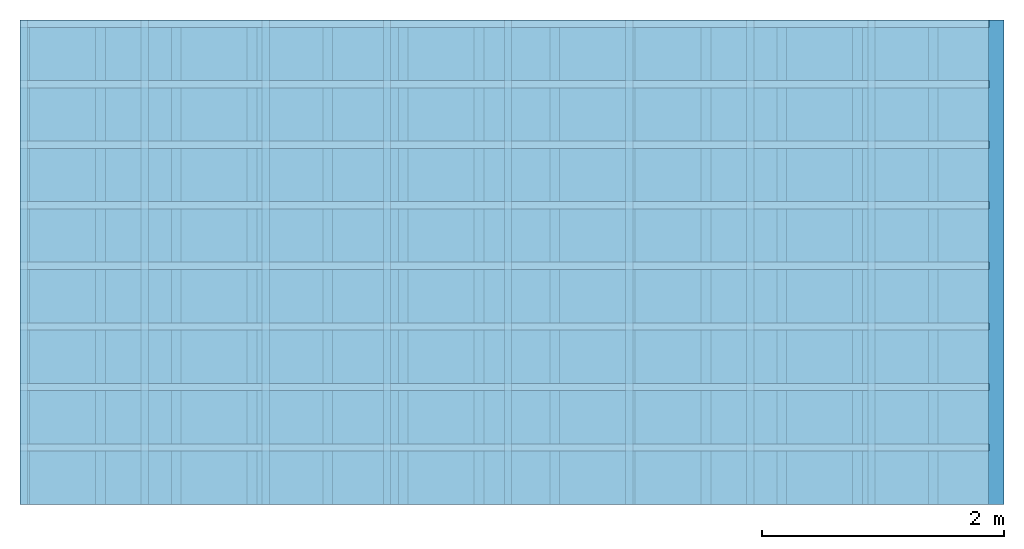
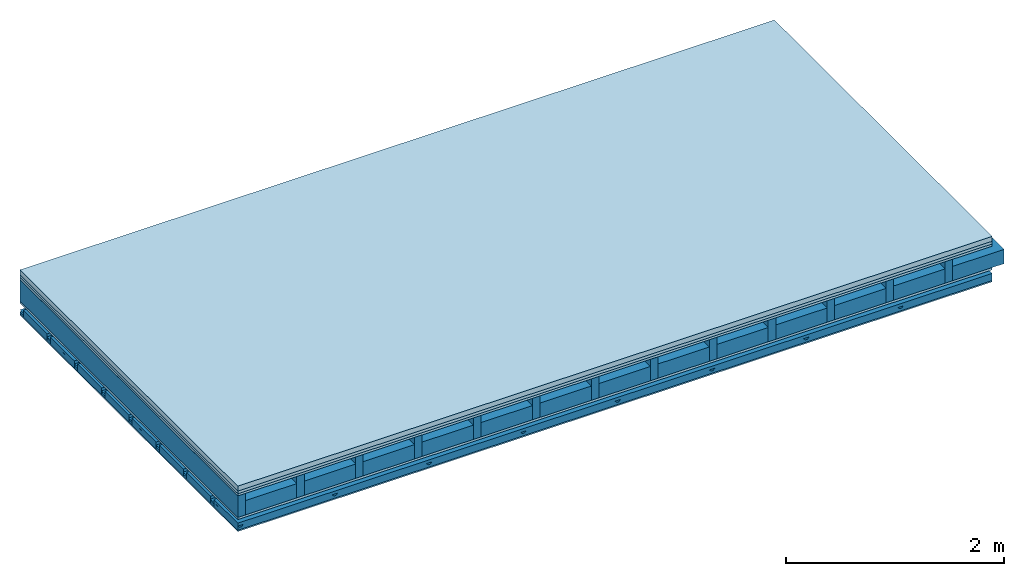
# One storey: 5 members, 5 plates, 1 element without a shape of its own.
"""IFC4 building model written with IfcOpenShell, lengths in metres."""

from ifc_helpers import new_model, si_unit, derived_unit, direction, frame, frame_2d, origin, origin_with_axes, place, context, project, spatial, polyline, rectangle, outline, extrude, material, layer, layer_set, type_object, element, aggregate, save


model = new_model("IFC4")

# Units and contexts
plan_context = context("Plan", 3, precision=1e-05, world=origin(), true_north=direction((0.0, 1.0)))
model_context = context("Model", 3, precision=1e-05, world=origin(), true_north=direction((0.0, 1.0)))
ifc_project = project(units=[si_unit("LENGTHUNIT", "METRE"), derived_unit("SOUNDPRESSUREUNIT", [(si_unit("PRESSUREUNIT", "PASCAL", prefix="MICRO"), 0)]), si_unit("ENERGYUNIT", "JOULE", prefix="MEGA"), si_unit("MASSUNIT", "GRAM", prefix="KILO"), derived_unit("THERMALTRANSMITTANCEUNIT", [(si_unit("POWERUNIT", "WATT"), 1), (si_unit("AREAUNIT", "SQUARE_METRE"), -1), (si_unit("THERMODYNAMICTEMPERATUREUNIT", "KELVIN"), -1)]), derived_unit("AREADENSITYUNIT", [(si_unit("MASSUNIT", "GRAM", prefix="KILO"), 1), (si_unit("AREAUNIT", "SQUARE_METRE"), -1)]), derived_unit("USERDEFINED", [(si_unit("ENERGYUNIT", "JOULE", prefix="MEGA"), 1), (si_unit("AREAUNIT", "SQUARE_METRE"), -1)])], contexts=[plan_context, model_context])

# Site, building, storey
site = spatial("IfcSite", under=ifc_project)
building_placement = place(None, origin())
building = spatial("IfcBuilding", under=site, at=building_placement)
storey_placement = place(building_placement, origin())
storey = spatial("IfcBuildingStorey", under=building, at=storey_placement)

# Slab, members, plates
ifc_material_1 = material(Category="04.005")
ifc_layer_1 = layer(ifc_material_1, 0.055, Name="On-material")
ifc_material_2 = material()
ifc_layer_2 = layer(ifc_material_2, 0.03, Name="Impact sound insulation")
ifc_material_3 = material(Category="07.001")
ifc_layer_3 = layer(ifc_material_3, 0.025, Name="Sub-floor")
ifc_material_4 = material(Name="Rigid, of the art")
ifc_layer_4 = layer(ifc_material_4, 0.0, Name="Bond")
ifc_layer_5 = layer(None, 0.24, Name="Supporting structure")
ifc_layer_6 = layer(ifc_material_4, 0.0, Name="Bond")
ifc_layer_7 = layer(ifc_material_3, 0.025, Name="Lower layer 1")
ifc_layer_8 = layer(None, 0.093, Name="Coupling")
ifc_layer_9 = layer(None, 0.027, Name="Battens / profiles")
ifc_material_5 = material(Category="03.007")
ifc_layer_10 = layer(ifc_material_5, 0.015, Name="Ceiling covering 1st layer")
ifc_material_6 = material(Name="Glued joints")
ifc_layer_11 = layer(ifc_material_6, 0.0, Name="Surface / treatment")
ifc_layer_set = layer_set([ifc_layer_1, ifc_layer_2, ifc_layer_3, ifc_layer_4, ifc_layer_5, ifc_layer_6, ifc_layer_7, ifc_layer_8, ifc_layer_9, ifc_layer_10, ifc_layer_11])
slab_type = type_object("IfcSlabType", Name="A0755", PredefinedType="NOTDEFINED", material=ifc_layer_set)
slab_placement = place(None, frame((0.0, 0.0, 0.0), z_axis=(0.0, 0.0, -1.0), x_axis=(1.0, 0.0, 0.0)))
slab = element("IfcSlab", 1, at=slab_placement, inside=storey, type_object=slab_type, material=ifc_layer_set, Name="Slab #1")
ifc_material_7 = material()
member_1_placement = place(slab_placement, origin())
member_1 = element("IfcMember", 2, at=member_1_placement, material=ifc_material_7, Name="Supporting structure", context=plan_context, shape_type="SweptSolid", body=[
    extrude(rectangle(XDim=0.08, YDim=0.24, at=frame_2d((0.04, 0.12), x_axis=(1.0, 0.0))), frame((0.0, 4.0, 0.11), z_axis=(0.0, -1.0, 0.0), x_axis=(1.0, 0.0, 0.0)), (0.0, 0.0, 1.0), 4.0),
    extrude(rectangle(XDim=0.08, YDim=0.24, at=frame_2d((0.04, 0.12), x_axis=(1.0, 0.0))), frame((0.625, 4.0, 0.11), z_axis=(0.0, -1.0, 0.0), x_axis=(1.0, 0.0, 0.0)), (0.0, 0.0, 1.0), 4.0),
    extrude(rectangle(XDim=0.08, YDim=0.24, at=frame_2d((0.04, 0.12), x_axis=(1.0, 0.0))), frame((1.25, 4.0, 0.11), z_axis=(0.0, -1.0, 0.0), x_axis=(1.0, 0.0, 0.0)), (0.0, 0.0, 1.0), 4.0),
    extrude(rectangle(XDim=0.08, YDim=0.24, at=frame_2d((0.04, 0.12), x_axis=(1.0, 0.0))), frame((1.875, 4.0, 0.11), z_axis=(0.0, -1.0, 0.0), x_axis=(1.0, 0.0, 0.0)), (0.0, 0.0, 1.0), 4.0),
    extrude(rectangle(XDim=0.08, YDim=0.24, at=frame_2d((0.04, 0.12), x_axis=(1.0, 0.0))), frame((2.5, 4.0, 0.11), z_axis=(0.0, -1.0, 0.0), x_axis=(1.0, 0.0, 0.0)), (0.0, 0.0, 1.0), 4.0),
    extrude(rectangle(XDim=0.08, YDim=0.24, at=frame_2d((0.04, 0.12), x_axis=(1.0, 0.0))), frame((3.125, 4.0, 0.11), z_axis=(0.0, -1.0, 0.0), x_axis=(1.0, 0.0, 0.0)), (0.0, 0.0, 1.0), 4.0),
    extrude(rectangle(XDim=0.08, YDim=0.24, at=frame_2d((0.04, 0.12), x_axis=(1.0, 0.0))), frame((3.75, 4.0, 0.11), z_axis=(0.0, -1.0, 0.0), x_axis=(1.0, 0.0, 0.0)), (0.0, 0.0, 1.0), 4.0),
    extrude(rectangle(XDim=0.08, YDim=0.24, at=frame_2d((0.04, 0.12), x_axis=(1.0, 0.0))), frame((4.375, 4.0, 0.11), z_axis=(0.0, -1.0, 0.0), x_axis=(1.0, 0.0, 0.0)), (0.0, 0.0, 1.0), 4.0),
    extrude(rectangle(XDim=0.08, YDim=0.24, at=frame_2d((0.04, 0.12), x_axis=(1.0, 0.0))), frame((5.0, 4.0, 0.11), z_axis=(0.0, -1.0, 0.0), x_axis=(1.0, 0.0, 0.0)), (0.0, 0.0, 1.0), 4.0),
    extrude(rectangle(XDim=0.08, YDim=0.24, at=frame_2d((0.04, 0.12), x_axis=(1.0, 0.0))), frame((5.625, 4.0, 0.11), z_axis=(0.0, -1.0, 0.0), x_axis=(1.0, 0.0, 0.0)), (0.0, 0.0, 1.0), 4.0),
    extrude(rectangle(XDim=0.08, YDim=0.24, at=frame_2d((0.04, 0.12), x_axis=(1.0, 0.0))), frame((6.25, 4.0, 0.11), z_axis=(0.0, -1.0, 0.0), x_axis=(1.0, 0.0, 0.0)), (0.0, 0.0, 1.0), 4.0),
    extrude(rectangle(XDim=0.08, YDim=0.24, at=frame_2d((0.04, 0.12), x_axis=(1.0, 0.0))), frame((6.875, 4.0, 0.11), z_axis=(0.0, -1.0, 0.0), x_axis=(1.0, 0.0, 0.0)), (0.0, 0.0, 1.0), 4.0),
    extrude(rectangle(XDim=0.08, YDim=0.24, at=frame_2d((0.04, 0.12), x_axis=(1.0, 0.0))), frame((7.5, 4.0, 0.11), z_axis=(0.0, -1.0, 0.0), x_axis=(1.0, 0.0, 0.0)), (0.0, 0.0, 1.0), 4.0),
])
ifc_material_8 = material()
member_2_placement = place(slab_placement, origin())
member_2 = element("IfcMember", 3, at=member_2_placement, material=ifc_material_8, Name="in supporting structure", context=plan_context, shape_type="SweptSolid", body=[
    extrude(rectangle(XDim=0.545, YDim=0.16, at=frame_2d((0.2725, 0.08), x_axis=(1.0, 0.0))), frame((0.08, 4.0, 0.19), z_axis=(0.0, -1.0, 0.0), x_axis=(1.0, 0.0, 0.0)), (0.0, 0.0, 1.0), 4.0),
    extrude(rectangle(XDim=0.545, YDim=0.16, at=frame_2d((0.2725, 0.08), x_axis=(1.0, 0.0))), frame((0.705, 4.0, 0.19), z_axis=(0.0, -1.0, 0.0), x_axis=(1.0, 0.0, 0.0)), (0.0, 0.0, 1.0), 4.0),
    extrude(rectangle(XDim=0.545, YDim=0.16, at=frame_2d((0.2725, 0.08), x_axis=(1.0, 0.0))), frame((1.33, 4.0, 0.19), z_axis=(0.0, -1.0, 0.0), x_axis=(1.0, 0.0, 0.0)), (0.0, 0.0, 1.0), 4.0),
    extrude(rectangle(XDim=0.545, YDim=0.16, at=frame_2d((0.2725, 0.08), x_axis=(1.0, 0.0))), frame((1.955, 4.0, 0.19), z_axis=(0.0, -1.0, 0.0), x_axis=(1.0, 0.0, 0.0)), (0.0, 0.0, 1.0), 4.0),
    extrude(rectangle(XDim=0.545, YDim=0.16, at=frame_2d((0.2725, 0.08), x_axis=(1.0, 0.0))), frame((2.58, 4.0, 0.19), z_axis=(0.0, -1.0, 0.0), x_axis=(1.0, 0.0, 0.0)), (0.0, 0.0, 1.0), 4.0),
    extrude(rectangle(XDim=0.545, YDim=0.16, at=frame_2d((0.2725, 0.08), x_axis=(1.0, 0.0))), frame((3.205, 4.0, 0.19), z_axis=(0.0, -1.0, 0.0), x_axis=(1.0, 0.0, 0.0)), (0.0, 0.0, 1.0), 4.0),
    extrude(rectangle(XDim=0.545, YDim=0.16, at=frame_2d((0.2725, 0.08), x_axis=(1.0, 0.0))), frame((3.83, 4.0, 0.19), z_axis=(0.0, -1.0, 0.0), x_axis=(1.0, 0.0, 0.0)), (0.0, 0.0, 1.0), 4.0),
    extrude(rectangle(XDim=0.545, YDim=0.16, at=frame_2d((0.2725, 0.08), x_axis=(1.0, 0.0))), frame((4.455, 4.0, 0.19), z_axis=(0.0, -1.0, 0.0), x_axis=(1.0, 0.0, 0.0)), (0.0, 0.0, 1.0), 4.0),
    extrude(rectangle(XDim=0.545, YDim=0.16, at=frame_2d((0.2725, 0.08), x_axis=(1.0, 0.0))), frame((5.08, 4.0, 0.19), z_axis=(0.0, -1.0, 0.0), x_axis=(1.0, 0.0, 0.0)), (0.0, 0.0, 1.0), 4.0),
    extrude(rectangle(XDim=0.545, YDim=0.16, at=frame_2d((0.2725, 0.08), x_axis=(1.0, 0.0))), frame((5.705, 4.0, 0.19), z_axis=(0.0, -1.0, 0.0), x_axis=(1.0, 0.0, 0.0)), (0.0, 0.0, 1.0), 4.0),
    extrude(rectangle(XDim=0.545, YDim=0.16, at=frame_2d((0.2725, 0.08), x_axis=(1.0, 0.0))), frame((6.33, 4.0, 0.19), z_axis=(0.0, -1.0, 0.0), x_axis=(1.0, 0.0, 0.0)), (0.0, 0.0, 1.0), 4.0),
    extrude(rectangle(XDim=0.545, YDim=0.16, at=frame_2d((0.2725, 0.08), x_axis=(1.0, 0.0))), frame((6.955, 4.0, 0.19), z_axis=(0.0, -1.0, 0.0), x_axis=(1.0, 0.0, 0.0)), (0.0, 0.0, 1.0), 4.0),
    extrude(rectangle(XDim=0.545, YDim=0.16, at=frame_2d((0.2725, 0.08), x_axis=(1.0, 0.0))), frame((7.58, 4.0, 0.19), z_axis=(0.0, -1.0, 0.0), x_axis=(1.0, 0.0, 0.0)), (0.0, 0.0, 1.0), 4.0),
])
ifc_material_9 = material()
member_3_placement = place(slab_placement, origin())
member_3 = element("IfcMember", 4, at=member_3_placement, material=ifc_material_9, Name="Coupling", context=plan_context, shape_type="SweptSolid", body=[
    extrude(outline(polyline([(0.0, 0.0), (0.06, 0.0), (0.04, 0.02), (0.02, 0.02), (0.0, 0.0)])), frame((0.0, 4.0, 0.448), z_axis=(0.0, -1.0, 0.0), x_axis=(1.0, 0.0, 0.0)), (0.0, 0.0, 1.0), 4.0),
    extrude(outline(polyline([(0.0, 0.0), (0.06, 0.0), (0.04, 0.02), (0.02, 0.02), (0.0, 0.0)])), frame((1.0, 4.0, 0.448), z_axis=(0.0, -1.0, 0.0), x_axis=(1.0, 0.0, 0.0)), (0.0, 0.0, 1.0), 4.0),
    extrude(outline(polyline([(0.0, 0.0), (0.06, 0.0), (0.04, 0.02), (0.02, 0.02), (0.0, 0.0)])), frame((2.0, 4.0, 0.448), z_axis=(0.0, -1.0, 0.0), x_axis=(1.0, 0.0, 0.0)), (0.0, 0.0, 1.0), 4.0),
    extrude(outline(polyline([(0.0, 0.0), (0.06, 0.0), (0.04, 0.02), (0.02, 0.02), (0.0, 0.0)])), frame((3.0, 4.0, 0.448), z_axis=(0.0, -1.0, 0.0), x_axis=(1.0, 0.0, 0.0)), (0.0, 0.0, 1.0), 4.0),
    extrude(outline(polyline([(0.0, 0.0), (0.06, 0.0), (0.04, 0.02), (0.02, 0.02), (0.0, 0.0)])), frame((4.0, 4.0, 0.448), z_axis=(0.0, -1.0, 0.0), x_axis=(1.0, 0.0, 0.0)), (0.0, 0.0, 1.0), 4.0),
    extrude(outline(polyline([(0.0, 0.0), (0.06, 0.0), (0.04, 0.02), (0.02, 0.02), (0.0, 0.0)])), frame((5.0, 4.0, 0.448), z_axis=(0.0, -1.0, 0.0), x_axis=(1.0, 0.0, 0.0)), (0.0, 0.0, 1.0), 4.0),
    extrude(outline(polyline([(0.0, 0.0), (0.06, 0.0), (0.04, 0.02), (0.02, 0.02), (0.0, 0.0)])), frame((6.0, 4.0, 0.448), z_axis=(0.0, -1.0, 0.0), x_axis=(1.0, 0.0, 0.0)), (0.0, 0.0, 1.0), 4.0),
    extrude(outline(polyline([(0.0, 0.0), (0.06, 0.0), (0.04, 0.02), (0.02, 0.02), (0.0, 0.0)])), frame((7.0, 4.0, 0.448), z_axis=(0.0, -1.0, 0.0), x_axis=(1.0, 0.0, 0.0)), (0.0, 0.0, 1.0), 4.0),
])
ifc_material_10 = material()
member_4_placement = place(slab_placement, origin())
member_4 = element("IfcMember", 5, at=member_4_placement, material=ifc_material_10, Name="Battens / profiles", context=plan_context, shape_type="SweptSolid", body=[
    extrude(rectangle(XDim=0.06, YDim=0.027, at=frame_2d((0.03, 0.0135), x_axis=(1.0, 0.0))), frame((0.0, 0.0, 0.468), z_axis=(1.0, 0.0, 0.0), x_axis=(0.0, 1.0, 0.0)), (0.0, 0.0, 1.0), 8.0),
    extrude(rectangle(XDim=0.06, YDim=0.027, at=frame_2d((0.03, 0.0135), x_axis=(1.0, 0.0))), frame((0.0, 0.5, 0.468), z_axis=(1.0, 0.0, 0.0), x_axis=(0.0, 1.0, 0.0)), (0.0, 0.0, 1.0), 8.0),
    extrude(rectangle(XDim=0.06, YDim=0.027, at=frame_2d((0.03, 0.0135), x_axis=(1.0, 0.0))), frame((0.0, 1.0, 0.468), z_axis=(1.0, 0.0, 0.0), x_axis=(0.0, 1.0, 0.0)), (0.0, 0.0, 1.0), 8.0),
    extrude(rectangle(XDim=0.06, YDim=0.027, at=frame_2d((0.03, 0.0135), x_axis=(1.0, 0.0))), frame((0.0, 1.5, 0.468), z_axis=(1.0, 0.0, 0.0), x_axis=(0.0, 1.0, 0.0)), (0.0, 0.0, 1.0), 8.0),
    extrude(rectangle(XDim=0.06, YDim=0.027, at=frame_2d((0.03, 0.0135), x_axis=(1.0, 0.0))), frame((0.0, 2.0, 0.468), z_axis=(1.0, 0.0, 0.0), x_axis=(0.0, 1.0, 0.0)), (0.0, 0.0, 1.0), 8.0),
    extrude(rectangle(XDim=0.06, YDim=0.027, at=frame_2d((0.03, 0.0135), x_axis=(1.0, 0.0))), frame((0.0, 2.5, 0.468), z_axis=(1.0, 0.0, 0.0), x_axis=(0.0, 1.0, 0.0)), (0.0, 0.0, 1.0), 8.0),
    extrude(rectangle(XDim=0.06, YDim=0.027, at=frame_2d((0.03, 0.0135), x_axis=(1.0, 0.0))), frame((0.0, 3.0, 0.468), z_axis=(1.0, 0.0, 0.0), x_axis=(0.0, 1.0, 0.0)), (0.0, 0.0, 1.0), 8.0),
    extrude(rectangle(XDim=0.06, YDim=0.027, at=frame_2d((0.03, 0.0135), x_axis=(1.0, 0.0))), frame((0.0, 3.5, 0.468), z_axis=(1.0, 0.0, 0.0), x_axis=(0.0, 1.0, 0.0)), (0.0, 0.0, 1.0), 8.0),
])
ifc_material_11 = material()
member_5_placement = place(slab_placement, origin())
member_5 = element("IfcMember", 6, at=member_5_placement, material=ifc_material_11, Name="Cavity", context=plan_context, shape_type="SweptSolid", body=[
    extrude(rectangle(XDim=0.44, YDim=0.08, at=frame_2d((0.22, 0.04), x_axis=(1.0, 0.0))), frame((0.0, 0.06, 0.415), z_axis=(1.0, 0.0, 0.0), x_axis=(0.0, 1.0, 0.0)), (0.0, 0.0, 1.0), 8.0),
    extrude(rectangle(XDim=0.44, YDim=0.08, at=frame_2d((0.22, 0.04), x_axis=(1.0, 0.0))), frame((0.0, 0.56, 0.415), z_axis=(1.0, 0.0, 0.0), x_axis=(0.0, 1.0, 0.0)), (0.0, 0.0, 1.0), 8.0),
    extrude(rectangle(XDim=0.44, YDim=0.08, at=frame_2d((0.22, 0.04), x_axis=(1.0, 0.0))), frame((0.0, 1.06, 0.415), z_axis=(1.0, 0.0, 0.0), x_axis=(0.0, 1.0, 0.0)), (0.0, 0.0, 1.0), 8.0),
    extrude(rectangle(XDim=0.44, YDim=0.08, at=frame_2d((0.22, 0.04), x_axis=(1.0, 0.0))), frame((0.0, 1.56, 0.415), z_axis=(1.0, 0.0, 0.0), x_axis=(0.0, 1.0, 0.0)), (0.0, 0.0, 1.0), 8.0),
    extrude(rectangle(XDim=0.44, YDim=0.08, at=frame_2d((0.22, 0.04), x_axis=(1.0, 0.0))), frame((0.0, 2.06, 0.415), z_axis=(1.0, 0.0, 0.0), x_axis=(0.0, 1.0, 0.0)), (0.0, 0.0, 1.0), 8.0),
    extrude(rectangle(XDim=0.44, YDim=0.08, at=frame_2d((0.22, 0.04), x_axis=(1.0, 0.0))), frame((0.0, 2.56, 0.415), z_axis=(1.0, 0.0, 0.0), x_axis=(0.0, 1.0, 0.0)), (0.0, 0.0, 1.0), 8.0),
    extrude(rectangle(XDim=0.44, YDim=0.08, at=frame_2d((0.22, 0.04), x_axis=(1.0, 0.0))), frame((0.0, 3.06, 0.415), z_axis=(1.0, 0.0, 0.0), x_axis=(0.0, 1.0, 0.0)), (0.0, 0.0, 1.0), 8.0),
    extrude(rectangle(XDim=0.44, YDim=0.08, at=frame_2d((0.22, 0.04), x_axis=(1.0, 0.0))), frame((0.0, 3.56, 0.415), z_axis=(1.0, 0.0, 0.0), x_axis=(0.0, 1.0, 0.0)), (0.0, 0.0, 1.0), 8.0),
])
plate_1_placement = place(slab_placement, origin())
plate_1 = element("IfcPlate", 7, at=plate_1_placement, material=ifc_material_1, Name="On-material", context=plan_context, shape_type="SweptSolid", body=[
    extrude(rectangle(XDim=8.0, YDim=4.0, at=frame_2d((4.0, 2.0), x_axis=(1.0, 0.0))), origin_with_axes(), (0.0, 0.0, 1.0), 0.055),
])
plate_2_placement = place(slab_placement, origin())
plate_2 = element("IfcPlate", 8, at=plate_2_placement, material=ifc_material_2, Name="Impact sound insulation", context=plan_context, shape_type="SweptSolid", body=[
    extrude(rectangle(XDim=8.0, YDim=4.0, at=frame_2d((4.0, 2.0), x_axis=(1.0, 0.0))), frame((0.0, 0.0, 0.055), z_axis=(0.0, 0.0, 1.0), x_axis=(1.0, 0.0, 0.0)), (0.0, 0.0, 1.0), 0.03),
])
plate_3_placement = place(slab_placement, origin())
plate_3 = element("IfcPlate", 9, at=plate_3_placement, material=ifc_material_3, Name="Sub-floor", context=plan_context, shape_type="SweptSolid", body=[
    extrude(rectangle(XDim=8.0, YDim=4.0, at=frame_2d((4.0, 2.0), x_axis=(1.0, 0.0))), frame((0.0, 0.0, 0.085), z_axis=(0.0, 0.0, 1.0), x_axis=(1.0, 0.0, 0.0)), (0.0, 0.0, 1.0), 0.025),
])
plate_4_placement = place(slab_placement, origin())
plate_4 = element("IfcPlate", 10, at=plate_4_placement, material=ifc_material_3, Name="Lower layer 1", context=plan_context, shape_type="SweptSolid", body=[
    extrude(rectangle(XDim=8.0, YDim=4.0, at=frame_2d((4.0, 2.0), x_axis=(1.0, 0.0))), frame((0.0, 0.0, 0.35), z_axis=(0.0, 0.0, 1.0), x_axis=(1.0, 0.0, 0.0)), (0.0, 0.0, 1.0), 0.025),
])
plate_5_placement = place(slab_placement, origin())
plate_5 = element("IfcPlate", 11, at=plate_5_placement, material=ifc_material_5, Name="Ceiling covering 1st layer", context=plan_context, shape_type="SweptSolid", body=[
    extrude(rectangle(XDim=8.0, YDim=4.0, at=frame_2d((4.0, 2.0), x_axis=(1.0, 0.0))), frame((0.0, 0.0, 0.495), z_axis=(0.0, 0.0, 1.0), x_axis=(1.0, 0.0, 0.0)), (0.0, 0.0, 1.0), 0.015),
])
aggregate(slab, [plate_1, plate_2, plate_3, member_1, member_2, plate_4, member_3, member_4, member_5, plate_5])

save(model, "model.ifc")
